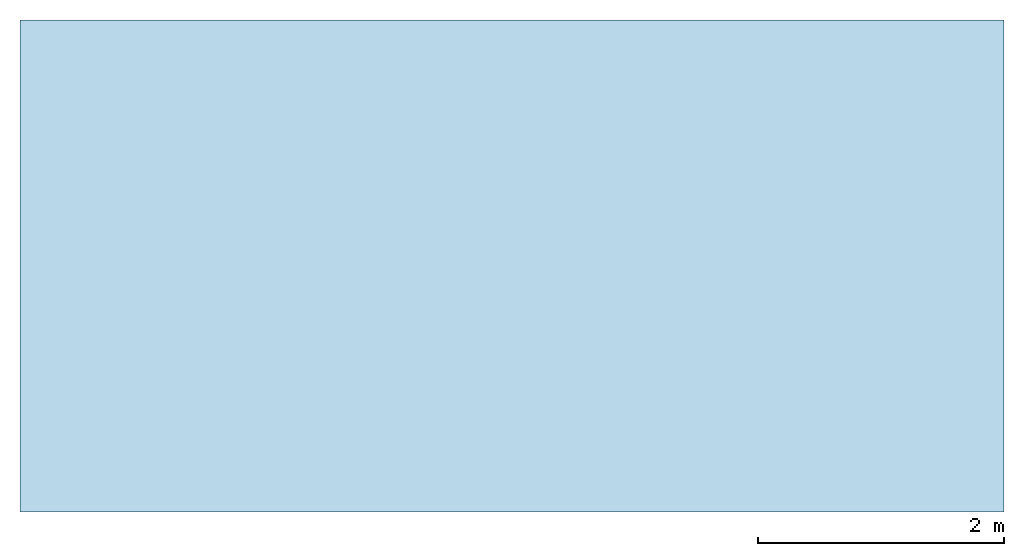
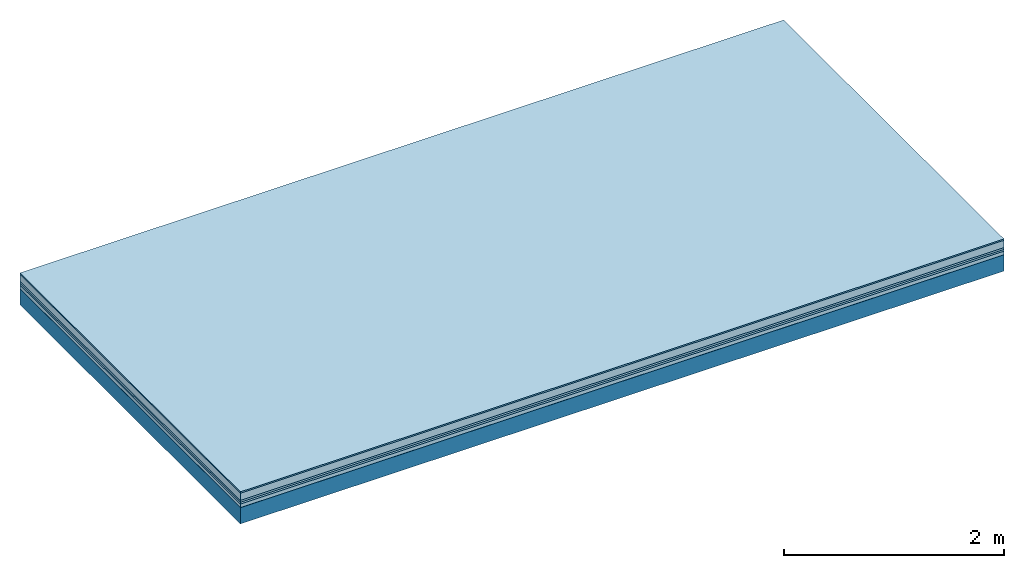
# One storey: 6 plates, 1 member, 1 element without a shape of its own.
"""IFC4 building model written with IfcOpenShell, lengths in metres."""

from ifc_helpers import new_model, si_unit, derived_unit, direction, frame, frame_2d, origin, origin_with_axes, place, context, project, spatial, rectangle, extrude, material, layer, layer_set, type_object, element, aggregate, save


model = new_model("IFC4")

# Units and contexts
plan_context = context("Plan", 3, precision=1e-05, world=origin(), true_north=direction((0.0, 1.0)))
model_context = context("Model", 3, precision=1e-05, world=origin(), true_north=direction((0.0, 1.0)))
ifc_project = project(units=[si_unit("LENGTHUNIT", "METRE"), derived_unit("SOUNDPRESSUREUNIT", [(si_unit("PRESSUREUNIT", "PASCAL", prefix="MICRO"), 0)]), si_unit("ENERGYUNIT", "JOULE", prefix="MEGA"), si_unit("MASSUNIT", "GRAM", prefix="KILO"), derived_unit("THERMALTRANSMITTANCEUNIT", [(si_unit("POWERUNIT", "WATT"), 1), (si_unit("AREAUNIT", "SQUARE_METRE"), -1), (si_unit("THERMODYNAMICTEMPERATUREUNIT", "KELVIN"), -1)]), derived_unit("AREADENSITYUNIT", [(si_unit("MASSUNIT", "GRAM", prefix="KILO"), 1), (si_unit("AREAUNIT", "SQUARE_METRE"), -1)]), derived_unit("USERDEFINED", [(si_unit("ENERGYUNIT", "JOULE", prefix="MEGA"), 1), (si_unit("AREAUNIT", "SQUARE_METRE"), -1)])], contexts=[plan_context, model_context])

# Site, building, storey
site = spatial("IfcSite", under=ifc_project)
building_placement = place(None, origin())
building = spatial("IfcBuilding", under=site, at=building_placement)
storey_placement = place(building_placement, origin())
storey = spatial("IfcBuildingStorey", under=building, at=storey_placement)

# Slab, member, plates
ifc_material_1 = material(Category="11.013")
ifc_layer_1 = layer(ifc_material_1, 0.015, Name="Flooring")
ifc_material_2 = material(Name="Cement screed", Category="04.006")
ifc_layer_2 = layer(ifc_material_2, 0.08, Name="On-material")
ifc_material_3 = material(Name="Wood fiber generic product", Category="10.009")
ifc_layer_3 = layer(ifc_material_3, 0.02, Name="Impact sound insulation")
ifc_material_4 = material()
ifc_layer_4 = layer(ifc_material_4, 0.02, Name="Additional insulation")
ifc_material_5 = material(Name="Cement panels, glued on sub-floor", Category="02.007")
ifc_layer_5 = layer(ifc_material_5, 0.04, Name="on Supporting structure")
ifc_material_6 = material(Name="protection", Category="09.007")
ifc_layer_6 = layer(ifc_material_6, 0.0005, Name="Sub-floor")
ifc_material_7 = material(Name="no composite action")
ifc_layer_7 = layer(ifc_material_7, 0.0, Name="Bond")
ifc_layer_8 = layer(None, 0.18, Name="Supporting structure")
ifc_layer_set = layer_set([ifc_layer_1, ifc_layer_2, ifc_layer_3, ifc_layer_4, ifc_layer_5, ifc_layer_6, ifc_layer_7, ifc_layer_8])
slab_type = type_object("IfcSlabType", Name="A2090", PredefinedType="NOTDEFINED", material=ifc_layer_set)
slab_placement = place(None, frame((0.0, 0.0, 0.0), z_axis=(0.0, 0.0, -1.0), x_axis=(1.0, 0.0, 0.0)))
slab = element("IfcSlab", 1, at=slab_placement, inside=storey, type_object=slab_type, material=ifc_layer_set, Name="Slab #1")
ifc_material_8 = material(Name="Solid timber panel")
member_placement = place(slab_placement, origin())
member = element("IfcMember", 2, at=member_placement, material=ifc_material_8, Name="Supporting structure", context=plan_context, shape_type="SweptSolid", body=[
    extrude(rectangle(XDim=1.0, YDim=0.18, at=frame_2d((0.5, 0.09), x_axis=(1.0, 0.0))), frame((0.0, 4.0, 0.1755), z_axis=(0.0, -1.0, 0.0), x_axis=(1.0, 0.0, 0.0)), (0.0, 0.0, 1.0), 4.0),
    extrude(rectangle(XDim=1.0, YDim=0.18, at=frame_2d((0.5, 0.09), x_axis=(1.0, 0.0))), frame((1.0, 4.0, 0.1755), z_axis=(0.0, -1.0, 0.0), x_axis=(1.0, 0.0, 0.0)), (0.0, 0.0, 1.0), 4.0),
    extrude(rectangle(XDim=1.0, YDim=0.18, at=frame_2d((0.5, 0.09), x_axis=(1.0, 0.0))), frame((2.0, 4.0, 0.1755), z_axis=(0.0, -1.0, 0.0), x_axis=(1.0, 0.0, 0.0)), (0.0, 0.0, 1.0), 4.0),
    extrude(rectangle(XDim=1.0, YDim=0.18, at=frame_2d((0.5, 0.09), x_axis=(1.0, 0.0))), frame((3.0, 4.0, 0.1755), z_axis=(0.0, -1.0, 0.0), x_axis=(1.0, 0.0, 0.0)), (0.0, 0.0, 1.0), 4.0),
    extrude(rectangle(XDim=1.0, YDim=0.18, at=frame_2d((0.5, 0.09), x_axis=(1.0, 0.0))), frame((4.0, 4.0, 0.1755), z_axis=(0.0, -1.0, 0.0), x_axis=(1.0, 0.0, 0.0)), (0.0, 0.0, 1.0), 4.0),
    extrude(rectangle(XDim=1.0, YDim=0.18, at=frame_2d((0.5, 0.09), x_axis=(1.0, 0.0))), frame((5.0, 4.0, 0.1755), z_axis=(0.0, -1.0, 0.0), x_axis=(1.0, 0.0, 0.0)), (0.0, 0.0, 1.0), 4.0),
    extrude(rectangle(XDim=1.0, YDim=0.18, at=frame_2d((0.5, 0.09), x_axis=(1.0, 0.0))), frame((6.0, 4.0, 0.1755), z_axis=(0.0, -1.0, 0.0), x_axis=(1.0, 0.0, 0.0)), (0.0, 0.0, 1.0), 4.0),
    extrude(rectangle(XDim=1.0, YDim=0.18, at=frame_2d((0.5, 0.09), x_axis=(1.0, 0.0))), frame((7.0, 4.0, 0.1755), z_axis=(0.0, -1.0, 0.0), x_axis=(1.0, 0.0, 0.0)), (0.0, 0.0, 1.0), 4.0),
])
plate_1_placement = place(slab_placement, origin())
plate_1 = element("IfcPlate", 3, at=plate_1_placement, material=ifc_material_1, Name="Flooring", context=plan_context, shape_type="SweptSolid", body=[
    extrude(rectangle(XDim=8.0, YDim=4.0, at=frame_2d((4.0, 2.0), x_axis=(1.0, 0.0))), origin_with_axes(), (0.0, 0.0, 1.0), 0.015),
])
plate_2_placement = place(slab_placement, origin())
plate_2 = element("IfcPlate", 4, at=plate_2_placement, material=ifc_material_2, Name="On-material", context=plan_context, shape_type="SweptSolid", body=[
    extrude(rectangle(XDim=8.0, YDim=4.0, at=frame_2d((4.0, 2.0), x_axis=(1.0, 0.0))), frame((0.0, 0.0, 0.015), z_axis=(0.0, 0.0, 1.0), x_axis=(1.0, 0.0, 0.0)), (0.0, 0.0, 1.0), 0.08),
])
plate_3_placement = place(slab_placement, origin())
plate_3 = element("IfcPlate", 5, at=plate_3_placement, material=ifc_material_3, Name="Impact sound insulation", context=plan_context, shape_type="SweptSolid", body=[
    extrude(rectangle(XDim=8.0, YDim=4.0, at=frame_2d((4.0, 2.0), x_axis=(1.0, 0.0))), frame((0.0, 0.0, 0.095), z_axis=(0.0, 0.0, 1.0), x_axis=(1.0, 0.0, 0.0)), (0.0, 0.0, 1.0), 0.02),
])
plate_4_placement = place(slab_placement, origin())
plate_4 = element("IfcPlate", 6, at=plate_4_placement, material=ifc_material_4, Name="Additional insulation", context=plan_context, shape_type="SweptSolid", body=[
    extrude(rectangle(XDim=8.0, YDim=4.0, at=frame_2d((4.0, 2.0), x_axis=(1.0, 0.0))), frame((0.0, 0.0, 0.115), z_axis=(0.0, 0.0, 1.0), x_axis=(1.0, 0.0, 0.0)), (0.0, 0.0, 1.0), 0.02),
])
plate_5_placement = place(slab_placement, origin())
plate_5 = element("IfcPlate", 7, at=plate_5_placement, material=ifc_material_5, Name="on Supporting structure", context=plan_context, shape_type="SweptSolid", body=[
    extrude(rectangle(XDim=8.0, YDim=4.0, at=frame_2d((4.0, 2.0), x_axis=(1.0, 0.0))), frame((0.0, 0.0, 0.135), z_axis=(0.0, 0.0, 1.0), x_axis=(1.0, 0.0, 0.0)), (0.0, 0.0, 1.0), 0.04),
])
plate_6_placement = place(slab_placement, origin())
plate_6 = element("IfcPlate", 8, at=plate_6_placement, material=ifc_material_6, Name="Sub-floor", context=plan_context, shape_type="SweptSolid", body=[
    extrude(rectangle(XDim=8.0, YDim=4.0, at=frame_2d((4.0, 2.0), x_axis=(1.0, 0.0))), frame((0.0, 0.0, 0.175), z_axis=(0.0, 0.0, 1.0), x_axis=(1.0, 0.0, 0.0)), (0.0, 0.0, 1.0), 0.0005),
])
aggregate(slab, [plate_1, plate_2, plate_3, plate_4, plate_5, plate_6, member])

save(model, "model.ifc")
